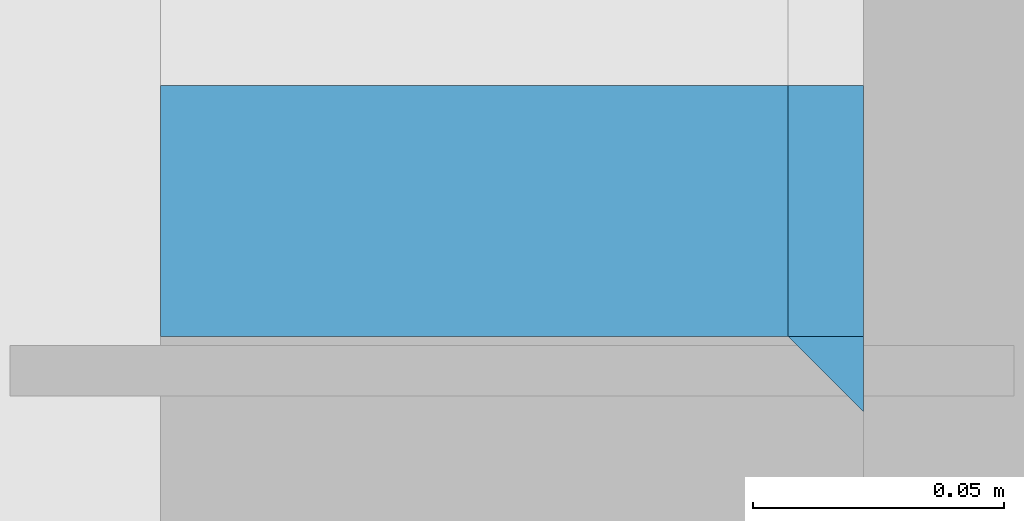
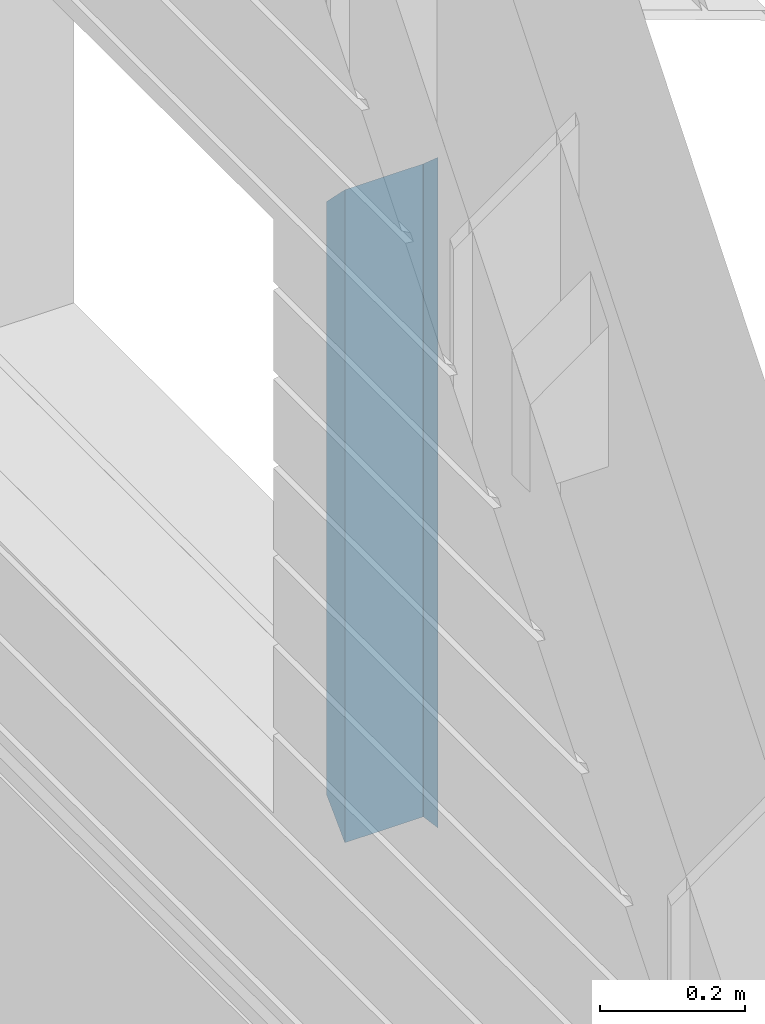
# One storey, part 23 of 153: 3 beams, 1 element without a shape of its own.
"""IFC2X3 building model written with IfcOpenShell, lengths in millimetres."""

from ifc_helpers import new_model, si_unit, frame, origin_with_axes, place, context, subcontext, project, spatial, faceted_brep, material, type_object, element, aggregate, save


model = new_model("IFC2X3")

# Units and contexts
model_context = context("Model", 3, precision=1e-05, world=origin_with_axes())
body_context = subcontext(model_context, "Body", "Model", "MODEL_VIEW")
ifc_project = project(units=[si_unit("LENGTHUNIT", "METRE", prefix="MILLI"), si_unit("AREAUNIT", "SQUARE_METRE"), si_unit("VOLUMEUNIT", "CUBIC_METRE"), si_unit("MASSUNIT", "GRAM", prefix="KILO"), si_unit("TIMEUNIT", "SECOND"), si_unit("PLANEANGLEUNIT", "RADIAN"), si_unit("SOLIDANGLEUNIT", "STERADIAN"), si_unit("THERMODYNAMICTEMPERATUREUNIT", "DEGREE_CELSIUS"), si_unit("LUMINOUSINTENSITYUNIT", "LUMEN")], contexts=[model_context])

# Site, building, storey
site_placement = place(None, origin_with_axes())
site = spatial("IfcSite", under=ifc_project, at=site_placement, CompositionType="ELEMENT")
building_placement = place(site_placement, origin_with_axes())
building = spatial("IfcBuilding", under=site, at=building_placement, CompositionType="ELEMENT")
storey_placement = place(building_placement, origin_with_axes())
storey = spatial("IfcBuildingStorey", under=building, at=storey_placement, Name="8", CompositionType="ELEMENT", Elevation=0.0)

# Assembly, beams
assembly_placement = place(storey_placement, origin_with_axes())
assembly = element("IfcElementAssembly", 1, at=assembly_placement, inside=storey, AssemblyPlace="NOTDEFINED", PredefinedType="REINFORCEMENT_UNIT")
ifc_material_1 = material(Name="CONCRETE/C25/30")
beam_type_1 = type_object("IfcBeamType", PredefinedType="NOTDEFINED")
beam_1_placement = place(assembly_placement, frame((7842.5, 17443.75, 105025.0), z_axis=(0.0, 1.0, 0.0), x_axis=(0.0, 0.0, -1.0)))
beam_1 = element("IfcBeam", 2, at=beam_1_placement, type_object=beam_type_1, material=ifc_material_1, context=body_context, shape_type="Brep", body=[
    faceted_brep([(15.0000000000036, 7.5, 7.5), (0.0, -7.5, -7.5), (15.0000000000036, -7.5, 7.5), (1115.0, -7.5, 7.5), (1115.0, 7.5, 7.5), (1130.0, -7.5, -7.5)], [[[0, 1, 2]], [[3, 4, 0, 2]], [[4, 5, 1, 0]], [[5, 3, 2, 1]], [[3, 5, 4]]]),
])
beam_type_2 = type_object("IfcBeamType", PredefinedType="NOTDEFINED")
beam_2_placement = place(assembly_placement, frame((7842.5, 17476.25, 105010.0), z_axis=(0.0, 1.0, 0.0), x_axis=(0.0, 0.0, -1.0)))
beam_2 = element("IfcBeam", 3, at=beam_2_placement, type_object=beam_type_2, material=ifc_material_1, context=body_context, shape_type="Brep", body=[
    faceted_brep([(50.0000000000036, 7.5, 25.0), (0.0, 7.5, -25.0), (0.0, -7.5, -25.0), (50.0, -7.5, 25.0), (1050.0, -7.5, 25.0), (1050.00000000001, 7.5, 25.0), (1100.0, 7.5, -25.0), (1100.0, -7.5, -25.0)], [[[0, 1, 2, 3]], [[4, 5, 0, 3]], [[5, 6, 1, 0]], [[6, 7, 2, 1]], [[7, 4, 3, 2]], [[5, 4, 7, 6]]]),
])
ifc_material_2 = material(Name="TIMBER")
beam_type_3 = type_object("IfcBeamType", Name="50X125", PredefinedType="NOTDEFINED")
beam_3_placement = place(assembly_placement, frame((7772.5, 17476.25, 105010.0), z_axis=(0.0, 1.0, 0.0), x_axis=(0.0, 0.0, -1.0)))
beam_3 = element("IfcBeam", 4, at=beam_3_placement, type_object=beam_type_3, material=ifc_material_2, ObjectType="50X125", context=body_context, shape_type="Brep", body=[
    faceted_brep([(49.9999999999818, 62.5, 25.0), (0.0, 62.5, -25.0), (0.0, -62.5, -25.0), (49.9999999999818, -62.5, 25.0), (1050.00000000001, -62.5, 25.0), (1050.00000000001, 62.5, 25.0), (1100.0, 62.5, -25.0), (1100.0, -62.5, -25.0)], [[[0, 1, 2, 3]], [[0, 3, 4, 5]], [[1, 0, 5, 6]], [[2, 1, 6, 7]], [[3, 2, 7, 4]], [[6, 5, 4, 7]]]),
])
aggregate(assembly, [beam_1, beam_2, beam_3])

save(model, "model.ifc")
